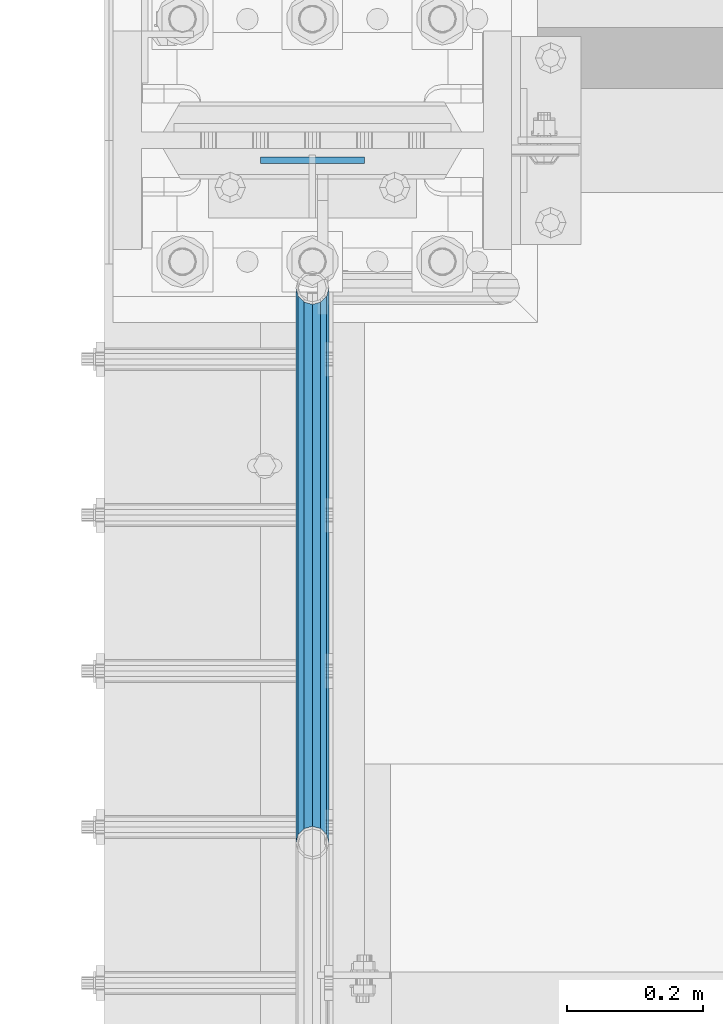
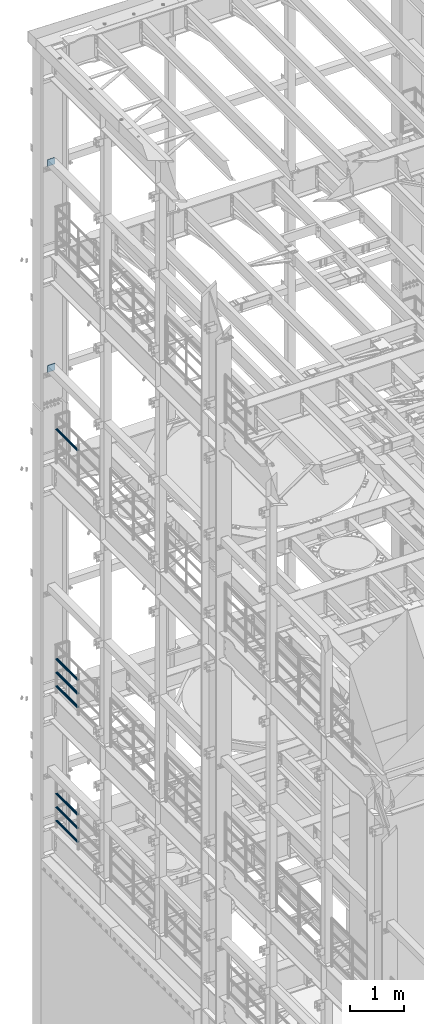
# One storey, part 1316 of 1876: 9 beams, 5 elements without a shape of their own.
"""IFC2X3 building model written with IfcOpenShell, lengths in millimetres."""

from ifc_helpers import new_model, si_unit, frame, origin_with_axes, place, context, subcontext, project, spatial, faceted_brep, material, type_object, element, aggregate, save


model = new_model("IFC2X3")

# Units and contexts
model_context = context("Model", 3, precision=1e-05, world=origin_with_axes())
body_context = subcontext(model_context, "Body", "Model", "MODEL_VIEW")
ifc_project = project(units=[si_unit("LENGTHUNIT", "METRE", prefix="MILLI"), si_unit("AREAUNIT", "SQUARE_METRE"), si_unit("VOLUMEUNIT", "CUBIC_METRE"), si_unit("MASSUNIT", "GRAM", prefix="KILO"), si_unit("TIMEUNIT", "SECOND"), si_unit("PLANEANGLEUNIT", "RADIAN"), si_unit("SOLIDANGLEUNIT", "STERADIAN"), si_unit("THERMODYNAMICTEMPERATUREUNIT", "DEGREE_CELSIUS"), si_unit("LUMINOUSINTENSITYUNIT", "LUMEN")], contexts=[model_context])

# Site, building, storey
site_placement = place(None, origin_with_axes())
site = spatial("IfcSite", under=ifc_project, at=site_placement, CompositionType="ELEMENT")
building_placement = place(site_placement, origin_with_axes())
building = spatial("IfcBuilding", under=site, at=building_placement, Name="Undefined", CompositionType="ELEMENT")
storey_placement = place(building_placement, origin_with_axes())
storey = spatial("IfcBuildingStorey", under=building, at=storey_placement, Name="Undefined", CompositionType="ELEMENT", Elevation=0.0)

# Assembly, beam
assembly_1_placement = place(storey_placement, origin_with_axes())
assembly_1 = element("IfcElementAssembly", 1, at=assembly_1_placement, inside=storey, Name="BEAM", AssemblyPlace="NOTDEFINED", PredefinedType="RIGID_FRAME")
ifc_material_1 = material(Name="STEEL/A36")
beam_type_1 = type_object("IfcBeamType", PredefinedType="NOTDEFINED")
beam_1_placement = place(assembly_1_placement, frame((76.1999999999998, 13686.63125, 19958.05), z_axis=(0.0, 0.0, -1.0), x_axis=(-1.0, 0.0, 0.0)))
beam_1 = element("IfcBeam", 2, at=beam_1_placement, type_object=beam_type_1, material=ifc_material_1, Name="PLATE", context=body_context, shape_type="Brep", body=[
    faceted_brep([(0.0, 4.76249999999982, -76.1999999999998), (3.63797880709171e-12, 4.76249999999982, 76.1999969482422), (152.399993896484, 4.76250000000073, 76.1999969482422), (152.4, 4.76249999999982, -76.1999999999998), (3.63797880709171e-12, -4.76249999999982, 76.1999969482422), (152.399993896484, -4.76250000000073, 76.1999969482422), (0.0, -4.76249999999982, -76.1999999999998), (152.4, -4.76249999999982, -76.1999999999998)], [[[0, 1, 2, 3]], [[4, 5, 2, 1]], [[4, 6, 7, 5]], [[6, 0, 3, 7]], [[5, 7, 3, 2]], [[6, 4, 1, 0]]]),
])
aggregate(assembly_1, [beam_1])

assembly_2_placement = place(storey_placement, origin_with_axes())
assembly_2 = element("IfcElementAssembly", 3, at=assembly_2_placement, inside=storey, Name="BEAM", AssemblyPlace="NOTDEFINED", PredefinedType="RIGID_FRAME")
beam_2_placement = place(assembly_2_placement, frame((76.1999999999998, 13686.63125, 15335.25), z_axis=(0.0, 0.0, -1.0), x_axis=(-1.0, 0.0, 0.0)))
beam_2 = element("IfcBeam", 4, at=beam_2_placement, type_object=beam_type_1, material=ifc_material_1, Name="PLATE", context=body_context, shape_type="Brep", body=[
    faceted_brep([(0.0, 4.76249999999982, -76.1999999999998), (3.63797880709171e-12, 4.76249999999982, 76.1999969482422), (152.399993896484, 4.76250000000073, 76.1999969482422), (152.4, 4.76249999999982, -76.1999999999998), (3.63797880709171e-12, -4.76249999999982, 76.1999969482422), (152.399993896484, -4.76250000000073, 76.1999969482422), (0.0, -4.76249999999982, -76.1999999999998), (152.4, -4.76249999999982, -76.1999999999998)], [[[0, 1, 2, 3]], [[4, 5, 2, 1]], [[4, 6, 7, 5]], [[6, 0, 3, 7]], [[5, 7, 3, 2]], [[6, 4, 1, 0]]]),
])
aggregate(assembly_2, [beam_2])

assembly_3_placement = place(storey_placement, origin_with_axes())
assembly_3 = element("IfcElementAssembly", 5, at=assembly_3_placement, inside=storey, Name="RAIL", AssemblyPlace="NOTDEFINED", PredefinedType="RIGID_FRAME")
ifc_material_2 = material()
beam_type_2 = type_object("IfcBeamType", Name="PIPE1-1/2SCH40", PredefinedType="NOTDEFINED")
beam_3_placement = place(assembly_3_placement, frame((-1.81898940354586e-12, 12686.3094, 14081.125), z_axis=(0.0, 0.0, -1.0), x_axis=(0.0, 1.0, 0.0)))
beam_3 = element("IfcBeam", 6, at=beam_3_placement, type_object=beam_type_2, material=ifc_material_2, Name="RAIL", ObjectType="PIPE1-1/2SCH40", context=body_context, shape_type="Brep", body=[
    faceted_brep([(0.0, 24.1299999999992, 0.0), (12.0650000000064, 20.8971929933177, -12.0649999999987), (12.0650000000064, 20.8971929933177, 12.0649999999987), (12.0650000000064, -20.8971929933177, 12.0649999999987), (12.0650000000064, -20.8971929933177, -12.0649999999987), (0.0, -24.1299999999992, 0.0), (20.8971929933249, -12.0650000000005, 20.8971929933177), (20.8971929933249, -12.0650000000005, 15.8661214311796), (15.2545715621445, -17.7076214311801, 10.2235000000001), (12.5151929933249, -20.4470000000001, 0.0), (15.2545715621445, -17.7076214311801, -10.2235000000001), (20.8971929933249, -12.0650000000005, -15.8661214311796), (20.8971929933249, -12.0650000000005, -20.8971929933177), (24.1300000000063, 0.0, -20.4470000000001), (24.1300000000063, 0.0, -24.130000000001), (21.3906214311868, -10.2235000000001, -17.7076214311819), (21.3906214311868, 10.2235000000001, -17.7076214311819), (20.8971929933249, 12.0650000000005, -15.8661214311796), (20.8971929933249, 12.0650000000005, -20.8971929933177), (15.2545715621445, 17.7076214311801, -10.2235000000001), (12.5151929933249, 20.4470000000001, 0.0), (15.2545715621445, 17.7076214311801, 10.2235000000001), (20.8971929933249, 12.0650000000005, 15.8661214311796), (20.8971929933249, 12.0650000000005, 20.8971929933177), (21.3906214311868, 10.2235000000001, 17.7076214311819), (24.1300000000064, 0.0, 20.4470000000001), (24.1300000000064, 0.0, 24.130000000001), (21.3906214311868, -10.2235000000001, 17.7076214311819), (813.396900000002, 24.1300000000001, 0.0), (801.331900000001, 20.8971929933186, -12.0649999999987), (792.499707006684, 12.0649999999996, -20.8971929933177), (813.396900000002, -24.1300000000319, 0.0), (801.331900000001, -20.8971929933186, -12.0649999999987), (801.331900000001, -20.8971929933186, 12.0649999999987), (792.499707006684, -12.0649999999996, 20.8971929933177), (792.499707006684, -12.0649999999996, -20.8971929933177), (789.266900000001, 0.0, -24.130000000001), (792.00627856883, 10.2235000000001, -17.7076214311819), (789.266900000001, 0.0, -20.4470000000001), (792.499707006684, 12.0649999999678, -15.8661214312124), (792.499707006684, -12.0650000000314, -15.8661214311469), (792.006278568813, -10.2235000000001, -17.7076214311819), (798.142328437831, -17.7076214311801, -10.2235000000001), (800.881707006651, -20.4470000000001, 0.0), (798.142328437831, -17.7076214311801, 10.2235000000001), (792.499707006684, -12.0650000000314, 15.8661214311469), (792.006278568813, -10.2235000000001, 17.7076214311819), (789.266900000001, -9.09494701772928e-13, 20.4470000000001), (789.266900000001, -9.09494701772928e-13, 24.130000000001), (792.499707006684, 12.0649999999996, 20.8971929933177), (801.331900000001, 20.8971929933186, 12.0649999999987), (792.499707006684, 12.0649999999678, 15.8661214312124), (798.142328437896, 17.7076214311801, 10.2235000000001), (800.881707006714, 20.4470000000001, 0.0), (798.142328437896, 17.7076214311801, -10.2235000000001), (792.00627856883, 10.2235000000001, 17.7076214311819)], [[[0, 1, 2]], [[3, 4, 5]], [[6, 7, 8, 9, 10, 11, 12, 4, 3]], [[13, 14, 12, 11, 15]], [[16, 17, 18, 14, 13]], [[2, 1, 18, 17, 19, 20, 21, 22, 23]], [[23, 22, 24, 25, 26]], [[26, 25, 27, 7, 6]], [[1, 0, 28, 29]], [[18, 1, 29, 30]], [[31, 32, 33]], [[6, 3, 33, 34]], [[3, 5, 31, 33]], [[5, 4, 32, 31]], [[4, 12, 35, 32]], [[12, 14, 36, 35]], [[14, 18, 30, 36]], [[37, 38, 36, 30, 39]], [[40, 35, 36, 38, 41]], [[33, 32, 35, 40, 42, 43, 44, 45, 34]], [[34, 45, 46, 47, 48]], [[26, 6, 34, 48]], [[2, 23, 49, 50]], [[23, 26, 48, 49]], [[0, 2, 50, 28]], [[28, 50, 29]], [[49, 51, 52, 53, 54, 39, 30, 29, 50]], [[48, 47, 55, 51, 49]], [[25, 24, 55, 47]], [[55, 24, 22, 21, 52, 51]], [[21, 20, 53, 52]], [[20, 19, 54, 53]], [[19, 17, 16, 37, 39, 54]], [[16, 13, 38, 37]], [[13, 15, 41, 38]], [[41, 15, 11, 10, 42, 40]], [[10, 9, 43, 42]], [[9, 8, 44, 43]], [[8, 7, 27, 46, 45, 44]], [[27, 25, 47, 46]]]),
])
aggregate(assembly_3, [beam_3])

# Assembly, beams
assembly_4_placement = place(storey_placement, origin_with_axes())
assembly_4 = element("IfcElementAssembly", 7, at=assembly_4_placement, inside=storey, Name="RAIL", AssemblyPlace="NOTDEFINED", PredefinedType="RIGID_FRAME")
beam_4_placement = place(assembly_4_placement, frame((1.81311423431267e-11, 13499.7063, 8315.325), z_axis=(0.0, 0.0, 1.0), x_axis=(0.0, -1.0, 0.0)))
beam_4 = element("IfcBeam", 8, at=beam_4_placement, type_object=beam_type_2, material=ifc_material_2, Name="RAIL", ObjectType="PIPE1-1/2SCH40", context=body_context, shape_type="Brep", body=[
    faceted_brep([(792.499707006684, -12.0649999999996, 20.8971929933177), (792.499707006684, -12.0650000000314, 15.8661214311469), (792.006278568813, -10.2235000000001, 17.7076214311819), (789.266900000001, -9.09494701772928e-13, 20.4470000000001), (789.266900000001, -9.09494701772928e-13, 24.130000000001), (792.00627856883, 10.2235000000001, 17.7076214311819), (792.499707006684, 12.0649999999678, 15.8661214312124), (792.499707006684, 12.0649999999996, 20.8971929933177), (813.396900000002, 24.1300000000001, 0.0), (801.331900000001, 20.8971929933186, 12.0649999999987), (801.331900000001, 20.8971929933186, -12.0649999999987), (798.142328437896, 17.7076214311801, 10.2235000000001), (800.881707006714, 20.4470000000001, 0.0), (798.142328437896, 17.7076214311801, -10.2235000000001), (792.499707006684, 12.0649999999678, -15.8661214312124), (792.499707006684, 12.0649999999996, -20.8971929933177), (792.00627856883, 10.2235000000001, -17.7076214311819), (789.266900000001, 0.0, -20.4470000000001), (789.266900000001, 0.0, -24.130000000001), (792.499707006684, -12.0650000000314, -15.8661214311469), (792.499707006684, -12.0649999999996, -20.8971929933177), (792.006278568813, -10.2235000000001, -17.7076214311819), (813.396900000002, -24.1300000000319, 0.0), (801.331900000001, -20.8971929933186, -12.0649999999987), (801.331900000001, -20.8971929933186, 12.0649999999987), (798.142328437831, -17.7076214311801, -10.2235000000001), (800.881707006651, -20.4470000000001, 0.0), (798.142328437831, -17.7076214311801, 10.2235000000001), (12.0650000000064, -20.8971929933177, -12.0649999999987), (20.8971929933249, -12.0650000000005, -20.8971929933177), (0.0, 24.1299999999992, 0.0), (12.0650000000064, 20.8971929933177, -12.0649999999987), (12.0650000000064, 20.8971929933177, 12.0649999999987), (20.8971929933249, 12.0650000000005, 20.8971929933177), (24.1300000000064, 0.0, 24.130000000001), (20.8971929933249, 12.0650000000005, -20.8971929933177), (24.1300000000063, 0.0, -24.130000000001), (24.1300000000063, 0.0, -20.4470000000001), (20.8971929933249, -12.0650000000005, -15.8661214311796), (21.3906214311868, -10.2235000000001, -17.7076214311819), (21.3906214311868, 10.2235000000001, -17.7076214311819), (20.8971929933249, 12.0650000000005, -15.8661214311796), (15.2545715621445, 17.7076214311801, -10.2235000000001), (12.5151929933249, 20.4470000000001, 0.0), (15.2545715621445, 17.7076214311801, 10.2235000000001), (20.8971929933249, 12.0650000000005, 15.8661214311796), (21.3906214311868, 10.2235000000001, 17.7076214311819), (24.1300000000064, 0.0, 20.4470000000001), (21.3906214311868, -10.2235000000001, 17.7076214311819), (20.8971929933249, -12.0650000000005, 15.8661214311796), (20.8971929933249, -12.0650000000005, 20.8971929933177), (12.0650000000064, -20.8971929933177, 12.0649999999987), (0.0, -24.1299999999992, 0.0), (15.2545715621445, -17.7076214311801, 10.2235000000001), (12.5151929933249, -20.4470000000001, 0.0), (15.2545715621445, -17.7076214311801, -10.2235000000001)], [[[0, 1, 2, 3, 4]], [[4, 3, 5, 6, 7]], [[8, 9, 10]], [[7, 6, 11, 12, 13, 14, 15, 10, 9]], [[16, 17, 18, 15, 14]], [[19, 20, 18, 17, 21]], [[22, 23, 24]], [[24, 23, 20, 19, 25, 26, 27, 1, 0]], [[28, 29, 20, 23]], [[30, 31, 32]], [[33, 34, 4, 7]], [[32, 33, 7, 9]], [[30, 32, 9, 8]], [[31, 30, 8, 10]], [[35, 31, 10, 15]], [[36, 35, 15, 18]], [[29, 36, 18, 20]], [[37, 36, 29, 38, 39]], [[40, 41, 35, 36, 37]], [[32, 31, 35, 41, 42, 43, 44, 45, 33]], [[33, 45, 46, 47, 34]], [[34, 47, 48, 49, 50]], [[34, 50, 0, 4]], [[50, 51, 24, 0]], [[51, 52, 22, 24]], [[52, 28, 23, 22]], [[51, 28, 52]], [[50, 49, 53, 54, 55, 38, 29, 28, 51]], [[55, 54, 26, 25]], [[21, 39, 38, 55, 25, 19]], [[37, 39, 21, 17]], [[40, 37, 17, 16]], [[42, 41, 40, 16, 14, 13]], [[43, 42, 13, 12]], [[44, 43, 12, 11]], [[5, 46, 45, 44, 11, 6]], [[47, 46, 5, 3]], [[48, 47, 3, 2]], [[53, 49, 48, 2, 1, 27]], [[54, 53, 27, 26]]]),
])
beam_5_placement = place(assembly_4_placement, frame((-1.81898940354586e-12, 12686.3094, 8620.125), z_axis=(0.0, 0.0, -1.0), x_axis=(0.0, 1.0, 0.0)))
beam_5 = element("IfcBeam", 9, at=beam_5_placement, type_object=beam_type_2, material=ifc_material_2, Name="RAIL", ObjectType="PIPE1-1/2SCH40", context=body_context, shape_type="Brep", body=[
    faceted_brep([(0.0, 24.1299999999992, 0.0), (12.0650000000064, 20.8971929933177, -12.0649999999987), (12.0650000000064, 20.8971929933177, 12.0649999999987), (12.0650000000064, -20.8971929933177, 12.0649999999987), (12.0650000000064, -20.8971929933177, -12.0649999999987), (0.0, -24.1299999999992, 0.0), (20.8971929933249, -12.0650000000005, 20.8971929933177), (20.8971929933249, -12.0650000000005, 15.8661214311796), (15.2545715621445, -17.7076214311801, 10.2235000000001), (12.5151929933249, -20.4470000000001, 0.0), (15.2545715621445, -17.7076214311801, -10.2235000000001), (20.8971929933249, -12.0650000000005, -15.8661214311796), (20.8971929933249, -12.0650000000005, -20.8971929933177), (24.1300000000063, 0.0, -20.4470000000001), (24.1300000000063, 0.0, -24.130000000001), (21.3906214311868, -10.2235000000001, -17.7076214311819), (21.3906214311868, 10.2235000000001, -17.7076214311819), (20.8971929933249, 12.0650000000005, -15.8661214311796), (20.8971929933249, 12.0650000000005, -20.8971929933177), (15.2545715621445, 17.7076214311801, -10.2235000000001), (12.5151929933249, 20.4470000000001, 0.0), (15.2545715621445, 17.7076214311801, 10.2235000000001), (20.8971929933249, 12.0650000000005, 15.8661214311796), (20.8971929933249, 12.0650000000005, 20.8971929933177), (21.3906214311868, 10.2235000000001, 17.7076214311819), (24.1300000000064, 0.0, 20.4470000000001), (24.1300000000064, 0.0, 24.130000000001), (21.3906214311868, -10.2235000000001, 17.7076214311819), (813.396900000002, 24.1300000000001, 0.0), (801.331900000001, 20.8971929933186, -12.0649999999987), (792.499707006684, 12.0649999999996, -20.8971929933177), (813.396900000002, -24.1300000000319, 0.0), (801.331900000001, -20.8971929933186, -12.0649999999987), (801.331900000001, -20.8971929933186, 12.0649999999987), (792.499707006684, -12.0649999999996, 20.8971929933177), (792.499707006684, -12.0649999999996, -20.8971929933177), (789.266900000001, 0.0, -24.130000000001), (792.00627856883, 10.2235000000001, -17.7076214311819), (789.266900000001, 0.0, -20.4470000000001), (792.499707006684, 12.0649999999678, -15.8661214312124), (792.499707006684, -12.0650000000314, -15.8661214311469), (792.006278568813, -10.2235000000001, -17.7076214311819), (798.142328437831, -17.7076214311801, -10.2235000000001), (800.881707006651, -20.4470000000001, 0.0), (798.142328437831, -17.7076214311801, 10.2235000000001), (792.499707006684, -12.0650000000314, 15.8661214311469), (792.006278568813, -10.2235000000001, 17.7076214311819), (789.266900000001, -9.09494701772928e-13, 20.4470000000001), (789.266900000001, -9.09494701772928e-13, 24.130000000001), (792.499707006684, 12.0649999999996, 20.8971929933177), (801.331900000001, 20.8971929933186, 12.0649999999987), (792.499707006684, 12.0649999999678, 15.8661214312124), (798.142328437896, 17.7076214311801, 10.2235000000001), (800.881707006714, 20.4470000000001, 0.0), (798.142328437896, 17.7076214311801, -10.2235000000001), (792.00627856883, 10.2235000000001, 17.7076214311819)], [[[0, 1, 2]], [[3, 4, 5]], [[6, 7, 8, 9, 10, 11, 12, 4, 3]], [[13, 14, 12, 11, 15]], [[16, 17, 18, 14, 13]], [[2, 1, 18, 17, 19, 20, 21, 22, 23]], [[23, 22, 24, 25, 26]], [[26, 25, 27, 7, 6]], [[1, 0, 28, 29]], [[18, 1, 29, 30]], [[31, 32, 33]], [[6, 3, 33, 34]], [[3, 5, 31, 33]], [[5, 4, 32, 31]], [[4, 12, 35, 32]], [[12, 14, 36, 35]], [[14, 18, 30, 36]], [[37, 38, 36, 30, 39]], [[40, 35, 36, 38, 41]], [[33, 32, 35, 40, 42, 43, 44, 45, 34]], [[34, 45, 46, 47, 48]], [[26, 6, 34, 48]], [[2, 23, 49, 50]], [[23, 26, 48, 49]], [[0, 2, 50, 28]], [[28, 50, 29]], [[49, 51, 52, 53, 54, 39, 30, 29, 50]], [[48, 47, 55, 51, 49]], [[25, 24, 55, 47]], [[55, 24, 22, 21, 52, 51]], [[21, 20, 53, 52]], [[20, 19, 54, 53]], [[19, 17, 16, 37, 39, 54]], [[16, 13, 38, 37]], [[13, 15, 41, 38]], [[41, 15, 11, 10, 42, 40]], [[10, 9, 43, 42]], [[9, 8, 44, 43]], [[8, 7, 27, 46, 45, 44]], [[27, 25, 47, 46]]]),
])
beam_6_placement = place(assembly_4_placement, frame((-1.81898940354586e-12, 12686.3094, 8924.925), z_axis=(0.0, 0.0, -1.0), x_axis=(0.0, 1.0, 0.0)))
beam_6 = element("IfcBeam", 10, at=beam_6_placement, type_object=beam_type_2, material=ifc_material_2, Name="RAIL", ObjectType="PIPE1-1/2SCH40", context=body_context, shape_type="Brep", body=[
    faceted_brep([(0.0, 24.1299999999992, 0.0), (12.0650000000064, 20.8971929933177, -12.0649999999987), (12.0650000000064, 20.8971929933177, 12.0649999999987), (12.0650000000064, -20.8971929933177, 12.0649999999987), (12.0650000000064, -20.8971929933177, -12.0649999999987), (0.0, -24.1299999999992, 0.0), (20.8971929933249, -12.0650000000005, 20.8971929933177), (20.8971929933249, -12.0650000000005, 15.8661214311796), (15.2545715621445, -17.7076214311801, 10.2235000000001), (12.5151929933249, -20.4470000000001, 0.0), (15.2545715621445, -17.7076214311801, -10.2235000000001), (20.8971929933249, -12.0650000000005, -15.8661214311796), (20.8971929933249, -12.0650000000005, -20.8971929933177), (24.1300000000063, 0.0, -20.4470000000001), (24.1300000000063, 0.0, -24.130000000001), (21.3906214311868, -10.2235000000001, -17.7076214311819), (21.3906214311868, 10.2235000000001, -17.7076214311819), (20.8971929933249, 12.0650000000005, -15.8661214311796), (20.8971929933249, 12.0650000000005, -20.8971929933177), (15.2545715621445, 17.7076214311801, -10.2235000000001), (12.5151929933249, 20.4470000000001, 0.0), (15.2545715621445, 17.7076214311801, 10.2235000000001), (20.8971929933249, 12.0650000000005, 15.8661214311796), (20.8971929933249, 12.0650000000005, 20.8971929933177), (21.3906214311868, 10.2235000000001, 17.7076214311819), (24.1300000000064, 0.0, 20.4470000000001), (24.1300000000064, 0.0, 24.130000000001), (21.3906214311868, -10.2235000000001, 17.7076214311819), (813.396900000002, 24.1300000000001, 0.0), (801.331900000001, 20.8971929933186, -12.0649999999987), (792.499707006684, 12.0649999999996, -20.8971929933177), (813.396900000002, -24.1300000000319, 0.0), (801.331900000001, -20.8971929933186, -12.0649999999987), (801.331900000001, -20.8971929933186, 12.0649999999987), (792.499707006684, -12.0649999999996, 20.8971929933177), (792.499707006684, -12.0649999999996, -20.8971929933177), (789.266900000001, 0.0, -24.130000000001), (792.00627856883, 10.2235000000001, -17.7076214311819), (789.266900000001, 0.0, -20.4470000000001), (792.499707006684, 12.0649999999678, -15.8661214312124), (792.499707006684, -12.0650000000314, -15.8661214311469), (792.006278568813, -10.2235000000001, -17.7076214311819), (798.142328437831, -17.7076214311801, -10.2235000000001), (800.881707006651, -20.4470000000001, 0.0), (798.142328437831, -17.7076214311801, 10.2235000000001), (792.499707006684, -12.0650000000314, 15.8661214311469), (792.006278568813, -10.2235000000001, 17.7076214311819), (789.266900000001, -9.09494701772928e-13, 20.4470000000001), (789.266900000001, -9.09494701772928e-13, 24.130000000001), (792.499707006684, 12.0649999999996, 20.8971929933177), (801.331900000001, 20.8971929933186, 12.0649999999987), (792.499707006684, 12.0649999999678, 15.8661214312124), (798.142328437896, 17.7076214311801, 10.2235000000001), (800.881707006714, 20.4470000000001, 0.0), (798.142328437896, 17.7076214311801, -10.2235000000001), (792.00627856883, 10.2235000000001, 17.7076214311819)], [[[0, 1, 2]], [[3, 4, 5]], [[6, 7, 8, 9, 10, 11, 12, 4, 3]], [[13, 14, 12, 11, 15]], [[16, 17, 18, 14, 13]], [[2, 1, 18, 17, 19, 20, 21, 22, 23]], [[23, 22, 24, 25, 26]], [[26, 25, 27, 7, 6]], [[1, 0, 28, 29]], [[18, 1, 29, 30]], [[31, 32, 33]], [[6, 3, 33, 34]], [[3, 5, 31, 33]], [[5, 4, 32, 31]], [[4, 12, 35, 32]], [[12, 14, 36, 35]], [[14, 18, 30, 36]], [[37, 38, 36, 30, 39]], [[40, 35, 36, 38, 41]], [[33, 32, 35, 40, 42, 43, 44, 45, 34]], [[34, 45, 46, 47, 48]], [[26, 6, 34, 48]], [[2, 23, 49, 50]], [[23, 26, 48, 49]], [[0, 2, 50, 28]], [[28, 50, 29]], [[49, 51, 52, 53, 54, 39, 30, 29, 50]], [[48, 47, 55, 51, 49]], [[25, 24, 55, 47]], [[55, 24, 22, 21, 52, 51]], [[21, 20, 53, 52]], [[20, 19, 54, 53]], [[19, 17, 16, 37, 39, 54]], [[16, 13, 38, 37]], [[13, 15, 41, 38]], [[41, 15, 11, 10, 42, 40]], [[10, 9, 43, 42]], [[9, 8, 44, 43]], [[8, 7, 27, 46, 45, 44]], [[27, 25, 47, 46]]]),
])
aggregate(assembly_4, [beam_4, beam_5, beam_6])

assembly_5_placement = place(storey_placement, origin_with_axes())
assembly_5 = element("IfcElementAssembly", 11, at=assembly_5_placement, inside=storey, Name="RAIL", AssemblyPlace="NOTDEFINED", PredefinedType="RIGID_FRAME")
beam_7_placement = place(assembly_5_placement, frame((1.81311423431267e-11, 13499.7063, 5292.725), z_axis=(0.0, 0.0, 1.0), x_axis=(0.0, -1.0, 0.0)))
beam_7 = element("IfcBeam", 12, at=beam_7_placement, type_object=beam_type_2, material=ifc_material_2, Name="RAIL", ObjectType="PIPE1-1/2SCH40", context=body_context, shape_type="Brep", body=[
    faceted_brep([(792.499707006684, -12.0649999999996, 20.8971929933177), (792.499707006684, -12.0650000000314, 15.8661214311469), (792.006278568813, -10.2235000000001, 17.7076214311819), (789.266900000001, -9.09494701772928e-13, 20.4470000000001), (789.266900000001, -9.09494701772928e-13, 24.130000000001), (792.00627856883, 10.2235000000001, 17.7076214311819), (792.499707006684, 12.0649999999678, 15.8661214312124), (792.499707006684, 12.0649999999996, 20.8971929933177), (813.396900000002, 24.1300000000001, 0.0), (801.331900000001, 20.8971929933186, 12.0649999999987), (801.331900000001, 20.8971929933186, -12.0649999999987), (798.142328437896, 17.7076214311801, 10.2235000000001), (800.881707006714, 20.4470000000001, 0.0), (798.142328437896, 17.7076214311801, -10.2235000000001), (792.499707006684, 12.0649999999678, -15.8661214312124), (792.499707006684, 12.0649999999996, -20.8971929933177), (792.00627856883, 10.2235000000001, -17.7076214311819), (789.266900000001, 0.0, -20.4470000000001), (789.266900000001, 0.0, -24.130000000001), (792.499707006684, -12.0650000000314, -15.8661214311469), (792.499707006684, -12.0649999999996, -20.8971929933177), (792.006278568813, -10.2235000000001, -17.7076214311819), (813.396900000002, -24.1300000000319, 0.0), (801.331900000001, -20.8971929933186, -12.0649999999987), (801.331900000001, -20.8971929933186, 12.0649999999987), (798.142328437831, -17.7076214311801, -10.2235000000001), (800.881707006651, -20.4470000000001, 0.0), (798.142328437831, -17.7076214311801, 10.2235000000001), (12.0650000000064, -20.8971929933177, -12.0649999999987), (20.8971929933249, -12.0650000000005, -20.8971929933177), (0.0, 24.1299999999992, 0.0), (12.0650000000064, 20.8971929933177, -12.0649999999987), (12.0650000000064, 20.8971929933177, 12.0649999999987), (20.8971929933249, 12.0650000000005, 20.8971929933177), (24.1300000000064, 0.0, 24.130000000001), (20.8971929933249, 12.0650000000005, -20.8971929933177), (24.1300000000063, 0.0, -24.130000000001), (24.1300000000063, 0.0, -20.4470000000001), (20.8971929933249, -12.0650000000005, -15.8661214311796), (21.3906214311868, -10.2235000000001, -17.7076214311819), (21.3906214311868, 10.2235000000001, -17.7076214311819), (20.8971929933249, 12.0650000000005, -15.8661214311796), (15.2545715621445, 17.7076214311801, -10.2235000000001), (12.5151929933249, 20.4470000000001, 0.0), (15.2545715621445, 17.7076214311801, 10.2235000000001), (20.8971929933249, 12.0650000000005, 15.8661214311796), (21.3906214311868, 10.2235000000001, 17.7076214311819), (24.1300000000064, 0.0, 20.4470000000001), (21.3906214311868, -10.2235000000001, 17.7076214311819), (20.8971929933249, -12.0650000000005, 15.8661214311796), (20.8971929933249, -12.0650000000005, 20.8971929933177), (12.0650000000064, -20.8971929933177, 12.0649999999987), (0.0, -24.1299999999992, 0.0), (15.2545715621445, -17.7076214311801, 10.2235000000001), (12.5151929933249, -20.4470000000001, 0.0), (15.2545715621445, -17.7076214311801, -10.2235000000001)], [[[0, 1, 2, 3, 4]], [[4, 3, 5, 6, 7]], [[8, 9, 10]], [[7, 6, 11, 12, 13, 14, 15, 10, 9]], [[16, 17, 18, 15, 14]], [[19, 20, 18, 17, 21]], [[22, 23, 24]], [[24, 23, 20, 19, 25, 26, 27, 1, 0]], [[28, 29, 20, 23]], [[30, 31, 32]], [[33, 34, 4, 7]], [[32, 33, 7, 9]], [[30, 32, 9, 8]], [[31, 30, 8, 10]], [[35, 31, 10, 15]], [[36, 35, 15, 18]], [[29, 36, 18, 20]], [[37, 36, 29, 38, 39]], [[40, 41, 35, 36, 37]], [[32, 31, 35, 41, 42, 43, 44, 45, 33]], [[33, 45, 46, 47, 34]], [[34, 47, 48, 49, 50]], [[34, 50, 0, 4]], [[50, 51, 24, 0]], [[51, 52, 22, 24]], [[52, 28, 23, 22]], [[51, 28, 52]], [[50, 49, 53, 54, 55, 38, 29, 28, 51]], [[55, 54, 26, 25]], [[21, 39, 38, 55, 25, 19]], [[37, 39, 21, 17]], [[40, 37, 17, 16]], [[42, 41, 40, 16, 14, 13]], [[43, 42, 13, 12]], [[44, 43, 12, 11]], [[5, 46, 45, 44, 11, 6]], [[47, 46, 5, 3]], [[48, 47, 3, 2]], [[53, 49, 48, 2, 1, 27]], [[54, 53, 27, 26]]]),
])
beam_8_placement = place(assembly_5_placement, frame((-1.81898940354586e-12, 12686.3094, 5597.525), z_axis=(0.0, 0.0, -1.0), x_axis=(0.0, 1.0, 0.0)))
beam_8 = element("IfcBeam", 13, at=beam_8_placement, type_object=beam_type_2, material=ifc_material_2, Name="RAIL", ObjectType="PIPE1-1/2SCH40", context=body_context, shape_type="Brep", body=[
    faceted_brep([(0.0, 24.1299999999992, 0.0), (12.0650000000064, 20.8971929933177, -12.0649999999987), (12.0650000000064, 20.8971929933177, 12.0649999999987), (12.0650000000064, -20.8971929933177, 12.0649999999987), (12.0650000000064, -20.8971929933177, -12.0649999999987), (0.0, -24.1299999999992, 0.0), (20.8971929933249, -12.0650000000005, 20.8971929933177), (20.8971929933249, -12.0650000000005, 15.8661214311796), (15.2545715621445, -17.7076214311801, 10.2235000000001), (12.5151929933249, -20.4470000000001, 0.0), (15.2545715621445, -17.7076214311801, -10.2235000000001), (20.8971929933249, -12.0650000000005, -15.8661214311796), (20.8971929933249, -12.0650000000005, -20.8971929933177), (24.1300000000063, 0.0, -20.4470000000001), (24.1300000000063, 0.0, -24.130000000001), (21.3906214311868, -10.2235000000001, -17.7076214311819), (21.3906214311868, 10.2235000000001, -17.7076214311819), (20.8971929933249, 12.0650000000005, -15.8661214311796), (20.8971929933249, 12.0650000000005, -20.8971929933177), (15.2545715621445, 17.7076214311801, -10.2235000000001), (12.5151929933249, 20.4470000000001, 0.0), (15.2545715621445, 17.7076214311801, 10.2235000000001), (20.8971929933249, 12.0650000000005, 15.8661214311796), (20.8971929933249, 12.0650000000005, 20.8971929933177), (21.3906214311868, 10.2235000000001, 17.7076214311819), (24.1300000000064, 0.0, 20.4470000000001), (24.1300000000064, 0.0, 24.130000000001), (21.3906214311868, -10.2235000000001, 17.7076214311819), (813.396900000002, 24.1300000000001, 0.0), (801.331900000001, 20.8971929933186, -12.0649999999987), (792.499707006684, 12.0649999999996, -20.8971929933177), (813.396900000002, -24.1300000000319, 0.0), (801.331900000001, -20.8971929933186, -12.0649999999987), (801.331900000001, -20.8971929933186, 12.0649999999987), (792.499707006684, -12.0649999999996, 20.8971929933177), (792.499707006684, -12.0649999999996, -20.8971929933177), (789.266900000001, 0.0, -24.130000000001), (792.00627856883, 10.2235000000001, -17.7076214311819), (789.266900000001, 0.0, -20.4470000000001), (792.499707006684, 12.0649999999678, -15.8661214312124), (792.499707006684, -12.0650000000314, -15.8661214311469), (792.006278568813, -10.2235000000001, -17.7076214311819), (798.142328437831, -17.7076214311801, -10.2235000000001), (800.881707006651, -20.4470000000001, 0.0), (798.142328437831, -17.7076214311801, 10.2235000000001), (792.499707006684, -12.0650000000314, 15.8661214311469), (792.006278568813, -10.2235000000001, 17.7076214311819), (789.266900000001, -9.09494701772928e-13, 20.4470000000001), (789.266900000001, -9.09494701772928e-13, 24.130000000001), (792.499707006684, 12.0649999999996, 20.8971929933177), (801.331900000001, 20.8971929933186, 12.0649999999987), (792.499707006684, 12.0649999999678, 15.8661214312124), (798.142328437896, 17.7076214311801, 10.2235000000001), (800.881707006714, 20.4470000000001, 0.0), (798.142328437896, 17.7076214311801, -10.2235000000001), (792.00627856883, 10.2235000000001, 17.7076214311819)], [[[0, 1, 2]], [[3, 4, 5]], [[6, 7, 8, 9, 10, 11, 12, 4, 3]], [[13, 14, 12, 11, 15]], [[16, 17, 18, 14, 13]], [[2, 1, 18, 17, 19, 20, 21, 22, 23]], [[23, 22, 24, 25, 26]], [[26, 25, 27, 7, 6]], [[1, 0, 28, 29]], [[18, 1, 29, 30]], [[31, 32, 33]], [[6, 3, 33, 34]], [[3, 5, 31, 33]], [[5, 4, 32, 31]], [[4, 12, 35, 32]], [[12, 14, 36, 35]], [[14, 18, 30, 36]], [[37, 38, 36, 30, 39]], [[40, 35, 36, 38, 41]], [[33, 32, 35, 40, 42, 43, 44, 45, 34]], [[34, 45, 46, 47, 48]], [[26, 6, 34, 48]], [[2, 23, 49, 50]], [[23, 26, 48, 49]], [[0, 2, 50, 28]], [[28, 50, 29]], [[49, 51, 52, 53, 54, 39, 30, 29, 50]], [[48, 47, 55, 51, 49]], [[25, 24, 55, 47]], [[55, 24, 22, 21, 52, 51]], [[21, 20, 53, 52]], [[20, 19, 54, 53]], [[19, 17, 16, 37, 39, 54]], [[16, 13, 38, 37]], [[13, 15, 41, 38]], [[41, 15, 11, 10, 42, 40]], [[10, 9, 43, 42]], [[9, 8, 44, 43]], [[8, 7, 27, 46, 45, 44]], [[27, 25, 47, 46]]]),
])
beam_9_placement = place(assembly_5_placement, frame((-1.81898940354586e-12, 12686.3094, 5902.325), z_axis=(0.0, 0.0, -1.0), x_axis=(0.0, 1.0, 0.0)))
beam_9 = element("IfcBeam", 14, at=beam_9_placement, type_object=beam_type_2, material=ifc_material_2, Name="RAIL", ObjectType="PIPE1-1/2SCH40", context=body_context, shape_type="Brep", body=[
    faceted_brep([(0.0, 24.1299999999992, 0.0), (12.0650000000064, 20.8971929933177, -12.0649999999987), (12.0650000000064, 20.8971929933177, 12.0649999999987), (12.0650000000064, -20.8971929933177, 12.0649999999987), (12.0650000000064, -20.8971929933177, -12.0649999999987), (0.0, -24.1299999999992, 0.0), (20.8971929933249, -12.0650000000005, 20.8971929933177), (20.8971929933249, -12.0650000000005, 15.8661214311796), (15.2545715621445, -17.7076214311801, 10.2235000000001), (12.5151929933249, -20.4470000000001, 0.0), (15.2545715621445, -17.7076214311801, -10.2235000000001), (20.8971929933249, -12.0650000000005, -15.8661214311796), (20.8971929933249, -12.0650000000005, -20.8971929933177), (24.1300000000063, 0.0, -20.4470000000001), (24.1300000000063, 0.0, -24.130000000001), (21.3906214311868, -10.2235000000001, -17.7076214311819), (21.3906214311868, 10.2235000000001, -17.7076214311819), (20.8971929933249, 12.0650000000005, -15.8661214311796), (20.8971929933249, 12.0650000000005, -20.8971929933177), (15.2545715621445, 17.7076214311801, -10.2235000000001), (12.5151929933249, 20.4470000000001, 0.0), (15.2545715621445, 17.7076214311801, 10.2235000000001), (20.8971929933249, 12.0650000000005, 15.8661214311796), (20.8971929933249, 12.0650000000005, 20.8971929933177), (21.3906214311868, 10.2235000000001, 17.7076214311819), (24.1300000000064, 0.0, 20.4470000000001), (24.1300000000064, 0.0, 24.130000000001), (21.3906214311868, -10.2235000000001, 17.7076214311819), (813.396900000002, 24.1300000000001, 0.0), (801.331900000001, 20.8971929933186, -12.0649999999987), (792.499707006684, 12.0649999999996, -20.8971929933177), (813.396900000002, -24.1300000000319, 0.0), (801.331900000001, -20.8971929933186, -12.0649999999987), (801.331900000001, -20.8971929933186, 12.0649999999987), (792.499707006684, -12.0649999999996, 20.8971929933177), (792.499707006684, -12.0649999999996, -20.8971929933177), (789.266900000001, 0.0, -24.130000000001), (792.00627856883, 10.2235000000001, -17.7076214311819), (789.266900000001, 0.0, -20.4470000000001), (792.499707006684, 12.0649999999678, -15.8661214312124), (792.499707006684, -12.0650000000314, -15.8661214311469), (792.006278568813, -10.2235000000001, -17.7076214311819), (798.142328437831, -17.7076214311801, -10.2235000000001), (800.881707006651, -20.4470000000001, 0.0), (798.142328437831, -17.7076214311801, 10.2235000000001), (792.499707006684, -12.0650000000314, 15.8661214311469), (792.006278568813, -10.2235000000001, 17.7076214311819), (789.266900000001, -9.09494701772928e-13, 20.4470000000001), (789.266900000001, -9.09494701772928e-13, 24.130000000001), (792.499707006684, 12.0649999999996, 20.8971929933177), (801.331900000001, 20.8971929933186, 12.0649999999987), (792.499707006684, 12.0649999999678, 15.8661214312124), (798.142328437896, 17.7076214311801, 10.2235000000001), (800.881707006714, 20.4470000000001, 0.0), (798.142328437896, 17.7076214311801, -10.2235000000001), (792.00627856883, 10.2235000000001, 17.7076214311819)], [[[0, 1, 2]], [[3, 4, 5]], [[6, 7, 8, 9, 10, 11, 12, 4, 3]], [[13, 14, 12, 11, 15]], [[16, 17, 18, 14, 13]], [[2, 1, 18, 17, 19, 20, 21, 22, 23]], [[23, 22, 24, 25, 26]], [[26, 25, 27, 7, 6]], [[1, 0, 28, 29]], [[18, 1, 29, 30]], [[31, 32, 33]], [[6, 3, 33, 34]], [[3, 5, 31, 33]], [[5, 4, 32, 31]], [[4, 12, 35, 32]], [[12, 14, 36, 35]], [[14, 18, 30, 36]], [[37, 38, 36, 30, 39]], [[40, 35, 36, 38, 41]], [[33, 32, 35, 40, 42, 43, 44, 45, 34]], [[34, 45, 46, 47, 48]], [[26, 6, 34, 48]], [[2, 23, 49, 50]], [[23, 26, 48, 49]], [[0, 2, 50, 28]], [[28, 50, 29]], [[49, 51, 52, 53, 54, 39, 30, 29, 50]], [[48, 47, 55, 51, 49]], [[25, 24, 55, 47]], [[55, 24, 22, 21, 52, 51]], [[21, 20, 53, 52]], [[20, 19, 54, 53]], [[19, 17, 16, 37, 39, 54]], [[16, 13, 38, 37]], [[13, 15, 41, 38]], [[41, 15, 11, 10, 42, 40]], [[10, 9, 43, 42]], [[9, 8, 44, 43]], [[8, 7, 27, 46, 45, 44]], [[27, 25, 47, 46]]]),
])
aggregate(assembly_5, [beam_7, beam_8, beam_9])

save(model, "model.ifc")
